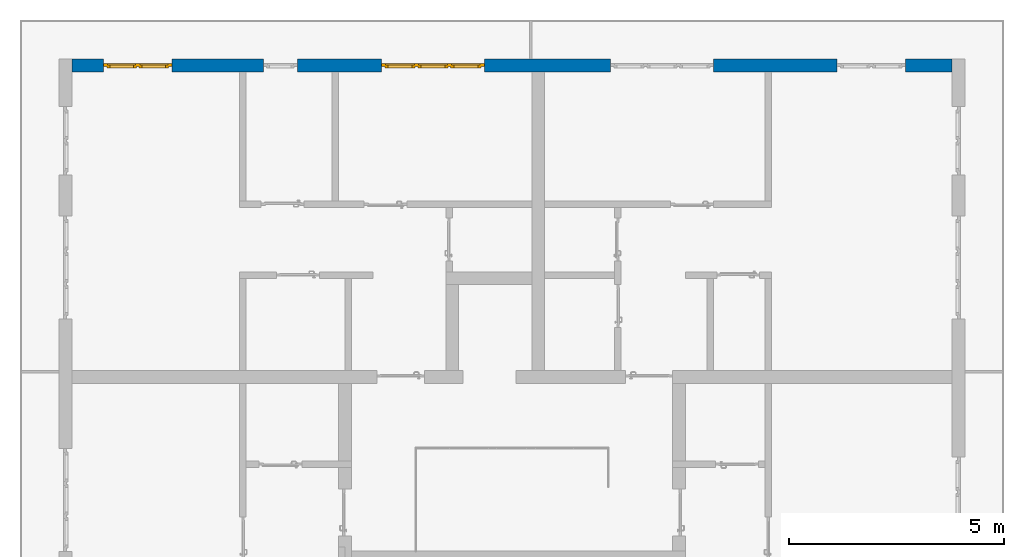
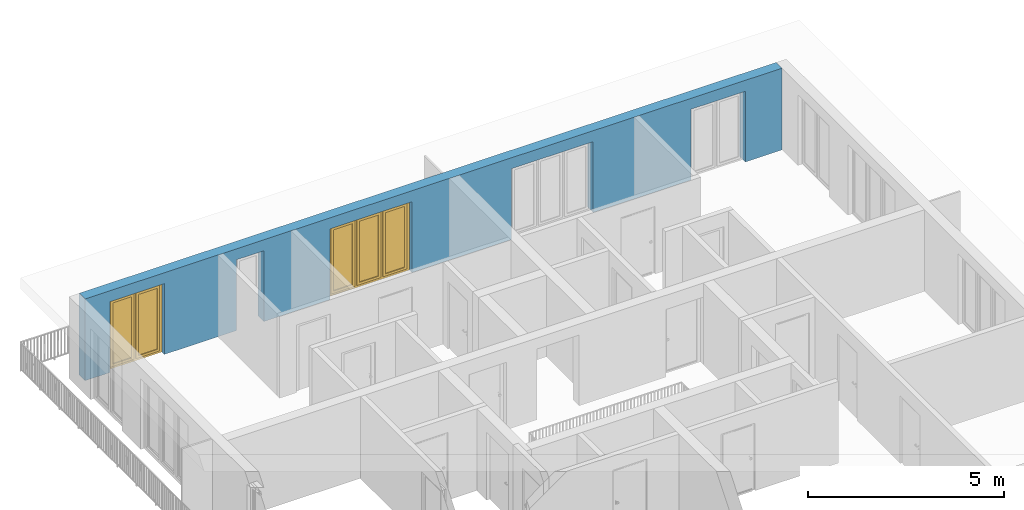
# One storey, part 27 of 54: 2 windows, 1 wall, 5 openings.
"""IFC4 building model written with IfcOpenShell, lengths in metres."""

from ifc_helpers import new_model, entity, si_unit, converted_unit, derived_unit, direction, frame, origin_with_axes, place, context, subcontext, project, spatial, polygons, source, transform, mapped, material, type_object, element, fill, save


model = new_model("IFC4")

# Units and contexts
model_context = context("Model", 3, precision=1e-05, world=origin_with_axes(), true_north=direction((0.0, 1.0)))
body_context = subcontext(model_context, "Body", "Model", "MODEL_VIEW")
ifc_project = project(units=[si_unit("LENGTHUNIT", "METRE"), si_unit("AREAUNIT", "SQUARE_METRE"), si_unit("VOLUMEUNIT", "CUBIC_METRE"), converted_unit("PLANEANGLEUNIT", "DEGREE", entity("IfcPlaneAngleMeasure", 0.0174532925199), si_unit("PLANEANGLEUNIT", "RADIAN"), dimensions=[0, 0, 0, 0, 0, 0, 0]), converted_unit("TIMEUNIT", "Year", entity("IfcTimeMeasure", 31556926.0), si_unit("TIMEUNIT", "SECOND"), dimensions=[0, 0, 1, 0, 0, 0, 0]), si_unit("MASSUNIT", "GRAM", prefix="KILO"), si_unit("THERMODYNAMICTEMPERATUREUNIT", "DEGREE_CELSIUS"), si_unit("LUMINOUSINTENSITYUNIT", "LUMEN"), si_unit("ENERGYUNIT", "JOULE", prefix="MEGA"), derived_unit("THERMALCONDUCTANCEUNIT", [(si_unit("POWERUNIT", "WATT"), 1), (si_unit("LENGTHUNIT", "METRE"), -1), (si_unit("THERMODYNAMICTEMPERATUREUNIT", "KELVIN"), -1)]), derived_unit("SPECIFICHEATCAPACITYUNIT", [(si_unit("ENERGYUNIT", "JOULE"), 1), (si_unit("MASSUNIT", "GRAM", prefix="KILO"), -1), (si_unit("THERMODYNAMICTEMPERATUREUNIT", "KELVIN"), -1)]), derived_unit("MASSDENSITYUNIT", [(si_unit("MASSUNIT", "GRAM", prefix="KILO"), 1), (si_unit("VOLUMEUNIT", "CUBIC_METRE"), -1)])], contexts=[model_context])

# Site, building, storey
site_placement = place(None, origin_with_axes())
site = spatial("IfcSite", under=ifc_project, at=site_placement, CompositionType="ELEMENT")
building_placement = place(site_placement, origin_with_axes())
building = spatial("IfcBuilding", under=site, at=building_placement, CompositionType="ELEMENT")
storey_placement = place(building_placement, frame((0.0, 0.0, 9.18), z_axis=(0.0, 0.0, 1.0), x_axis=(1.0, 0.0, 0.0)))
storey = spatial("IfcBuildingStorey", under=building, at=storey_placement, Name="3. Geschoss", CompositionType="ELEMENT", Elevation=9.18)

# Wall, openings, windows
ifc_material = material()
wall_type = type_object("IfcWallType", Name="300", PredefinedType="NOTDEFINED")
wall_placement = place(storey_placement, frame((-11.7421993804, 8.92118776896, 0.0), z_axis=(0.0, 0.0, 1.0), x_axis=(1.0, 0.0, 0.0)))
wall = element("IfcWall", 1, at=wall_placement, inside=storey, type_object=wall_type, material=ifc_material, Name="Wand-001", PredefinedType="NOTDEFINED", context=body_context, shape_type="Tessellation", body=[
    polygons([(15.23, -0.1, 0.0), (15.23, -0.3, 0.0), (15.23, -0.3, 2.2), (15.23, 0.0, 2.2), (15.23, 0.0, 0.0), (18.102139809, 0.0, 0.0), (18.102139809, -0.3, 0.0), (18.102139809, -0.3, 2.2), (19.702139809, -0.3, 2.2), (19.702139809, -0.3, 0.0), (20.78, -0.3, 0.0), (20.78, -0.3, 2.54), (0.3, -0.3, 2.54), (0.3, -0.3, 0.0), (1.0288518641, -0.3, 0.0), (1.0288518641, -0.3, 2.2), (2.6288518641, -0.3, 2.2), (2.6288518641, -0.3, 0.0), (4.75, -0.3, 0.0), (4.75, -0.3, 2.2), (5.55, -0.3, 2.2), (5.55, -0.3, 0.0), (7.50089858046, -0.3, 0.0), (7.50089858046, -0.3, 2.2), (9.90089858046, -0.3, 2.2), (9.90089858046, -0.3, 0.0), (12.83, -0.3, 0.0), (12.83, -0.3, 2.2), (12.83, 0.0, 2.2), (12.83, 0.0, 0.0), (9.90089858046, 0.0, 0.0), (9.90089858046, 0.0, 2.2), (7.50089858046, 0.0, 2.2), (7.50089858046, 0.0, 0.0), (5.55, 0.0, 0.0), (5.55, 0.0, 2.2), (4.75, 0.0, 2.2), (4.75, 0.0, 0.0), (2.6288518641, 0.0, 0.0), (2.6288518641, 0.0, 2.2), (1.0288518641, 0.0, 2.2), (1.0288518641, 0.0, 0.0), (0.3, 0.0, 0.0), (0.3, 0.0, 2.54), (20.78, 0.0, 2.54), (20.78, 0.0, 0.0), (19.702139809, 0.0, 0.0), (19.702139809, 0.0, 2.2), (18.102139809, 0.0, 2.2), (12.83, -0.1, 0.0)], [[[1, 2, 3, 4, 5]], [[2, 1, 5, 6, 7]], [[3, 2, 7, 8, 9, 10, 11, 12, 13, 14, 15, 16, 17, 18, 19, 20, 21, 22, 23, 24, 25, 26, 27, 28]], [[4, 3, 28, 29]], [[6, 5, 4, 29, 30, 31, 32, 33, 34, 35, 36, 37, 38, 39, 40, 41, 42, 43, 44, 45, 46, 47, 48, 49]], [[6, 49, 8, 7]], [[8, 49, 48, 9]], [[48, 47, 10, 9]], [[46, 11, 10, 47]], [[12, 11, 46, 45]], [[45, 44, 13, 12]], [[44, 43, 14, 13]], [[15, 14, 43, 42]], [[16, 15, 42, 41]], [[40, 17, 16, 41]], [[18, 17, 40, 39]], [[19, 18, 39, 38]], [[20, 19, 38, 37]], [[36, 21, 20, 37]], [[22, 21, 36, 35]], [[22, 35, 34, 23]], [[34, 33, 24, 23]], [[24, 33, 32, 25]], [[32, 31, 26, 25]], [[50, 27, 26, 31, 30]], [[28, 27, 50, 30, 29]]], closed=True),
])
opening_1_placement = place(wall_placement, frame((1.8288518641, 0.0, 0.0), z_axis=(0.0, 0.0, 1.0), x_axis=(1.0, 0.0, 0.0)))
opening_1 = element("IfcOpeningElement", 2, at=opening_1_placement, cuts=wall, Name="Fenster-001", context=body_context, identifier="Reference", shape_type="Tessellation", body=[
    polygons([(-0.8, -0.1, 0.0), (-0.8, -0.1, 2.2), (-0.8, 0.000999999999998, 2.2), (-0.8, 0.000999999999998, 0.0), (-0.8, -0.301, 0.0), (-0.8, -0.301, 2.2), (0.8, -0.1, 2.2), (0.8, 0.000999999999999, 2.2), (0.8, -0.301, 2.2), (0.8, 0.000999999999999, 0.0), (0.8, -0.1, 0.0), (0.8, -0.301, 0.0)], [[[1, 2, 3, 4]], [[2, 1, 5, 6]], [[7, 8, 3, 2, 6, 9]], [[8, 10, 4, 3]], [[1, 4, 10, 11, 12, 5]], [[6, 5, 12, 9]], [[7, 11, 10, 8]], [[11, 7, 9, 12]]], closed=True),
])
opening_2_placement = place(wall_placement, frame((8.70089858046, 0.0, 0.0), z_axis=(0.0, 0.0, 1.0), x_axis=(1.0, 0.0, 0.0)))
opening_2 = element("IfcOpeningElement", 3, at=opening_2_placement, cuts=wall, Name="Fenster-002", context=body_context, identifier="Reference", shape_type="Tessellation", body=[
    polygons([(-1.2, -0.1, 0.0), (-1.2, -0.1, 2.2), (-1.2, 0.000999999999999, 2.2), (-1.2, 0.000999999999999, 0.0), (-1.2, -0.301, 0.0), (-1.2, -0.301, 2.2), (1.2, -0.1, 2.2), (1.2, 0.001, 2.2), (1.2, -0.301, 2.2), (1.2, 0.001, 0.0), (1.2, -0.1, 0.0), (1.2, -0.301, 0.0)], [[[1, 2, 3, 4]], [[2, 1, 5, 6]], [[7, 8, 3, 2, 6, 9]], [[8, 10, 4, 3]], [[1, 4, 10, 11, 12, 5]], [[6, 5, 12, 9]], [[7, 11, 10, 8]], [[11, 7, 9, 12]]], closed=True),
])
opening_3_placement = place(wall_placement, frame((5.15, 0.0, 0.0), z_axis=(0.0, 0.0, 1.0), x_axis=(1.0, 0.0, 0.0)))
element("IfcOpeningElement", 4, at=opening_3_placement, cuts=wall, Name="Fenster-003", context=body_context, identifier="Reference", shape_type="Tessellation", body=[
    polygons([(-0.4, -0.1, 0.0), (-0.4, -0.1, 2.2), (-0.4, 0.001, 2.2), (-0.4, 0.001, 0.0), (-0.4, -0.301, 0.0), (-0.4, -0.301, 2.2), (0.4, -0.1, 2.2), (0.4, 0.001, 2.2), (0.4, -0.301, 2.2), (0.4, 0.001, 0.0), (0.4, -0.1, 0.0), (0.4, -0.301, 0.0)], [[[1, 2, 3, 4]], [[2, 1, 5, 6]], [[7, 8, 3, 2, 6, 9]], [[8, 10, 4, 3]], [[1, 4, 10, 11, 12, 5]], [[6, 5, 12, 9]], [[7, 11, 10, 8]], [[11, 7, 9, 12]]], closed=True),
])
opening_4_placement = place(wall_placement, frame((18.902139809, 0.0, 0.0), z_axis=(0.0, 0.0, 1.0), x_axis=(1.0, 0.0, 0.0)))
element("IfcOpeningElement", 5, at=opening_4_placement, cuts=wall, Name="Fenster-001", context=body_context, identifier="Reference", shape_type="Tessellation", body=[
    polygons([(-0.8, -0.1, 0.0), (-0.8, -0.1, 2.2), (-0.8, 0.001, 2.2), (-0.8, 0.001, 0.0), (-0.8, -0.301, 0.0), (-0.8, -0.301, 2.2), (0.8, -0.1, 2.2), (0.8, 0.001, 2.2), (0.8, -0.301, 2.2), (0.8, 0.001, 0.0), (0.8, -0.1, 0.0), (0.8, -0.301, 0.0)], [[[1, 2, 3, 4]], [[2, 1, 5, 6]], [[7, 8, 3, 2, 6, 9]], [[8, 10, 4, 3]], [[1, 4, 10, 11, 12, 5]], [[6, 5, 12, 9]], [[7, 11, 10, 8]], [[11, 7, 9, 12]]], closed=True),
])
opening_5_placement = place(wall_placement, frame((14.03, 0.0, 0.0), z_axis=(0.0, 0.0, 1.0), x_axis=(1.0, 0.0, 0.0)))
element("IfcOpeningElement", 6, at=opening_5_placement, cuts=wall, Name="Fenster-002", context=body_context, identifier="Reference", shape_type="Tessellation", body=[
    polygons([(-1.2, -0.1, 0.0), (-1.2, -0.1, 2.2), (-1.2, 0.001, 2.2), (-1.2, 0.001, 0.0), (-1.2, -0.301, 0.0), (-1.2, -0.301, 2.2), (1.2, -0.1, 2.2), (1.2, 0.001, 2.2), (1.2, -0.301, 2.2), (1.2, 0.001, 0.0), (1.2, -0.1, 0.0), (1.2, -0.301, 0.0)], [[[1, 2, 3, 4]], [[2, 1, 5, 6]], [[7, 8, 3, 2, 6, 9]], [[8, 10, 4, 3]], [[1, 4, 10, 11, 12, 5]], [[6, 5, 12, 9]], [[7, 11, 10, 8]], [[11, 7, 9, 12]]], closed=True),
])
window_type_1 = type_object("IfcWindowType", Name="2-1+1 26", PartitioningType="DOUBLE_PANEL_VERTICAL", PredefinedType="WINDOW")
shared_shape_1 = source(origin_with_axes(), body_context, "Body", "Tessellation", [
    polygons([(0.8, -0.07, 0.0), (0.7, -0.07, 0.1), (0.7, 0.0, 0.1), (0.8, 0.0, 0.0), (0.8, -0.07, 2.2), (0.7, -0.07, 2.1), (0.7, 0.0, 2.1), (0.8, 0.0, 2.2)], [[[1, 2, 3, 4]], [[1, 5, 6, 2]], [[2, 6, 7, 3]], [[4, 3, 7, 8]], [[5, 1, 4, 8]], [[6, 5, 8, 7]]], closed=True),
    polygons([(-0.8, -0.07, 0.0), (-0.8, -0.07, 2.2), (-0.8, 0.0, 2.2), (-0.8, 0.0, 0.0), (-0.7, -0.07, 0.1), (-0.7, -0.07, 2.1), (-0.7, 0.0, 2.1), (-0.7, 0.0, 0.1)], [[[1, 2, 3, 4]], [[1, 5, 6, 2]], [[2, 6, 7, 3]], [[4, 3, 7, 8]], [[5, 1, 4, 8]], [[6, 5, 8, 7]]], closed=True),
    polygons([(0.8, -0.07, 0.0), (-0.8, -0.07, 0.0), (-0.8, 0.0, 0.0), (0.8, 0.0, 0.0), (0.7, -0.07, 0.1), (0.05, -0.07, 0.1), (-0.05, -0.07, 0.1), (-0.7, -0.07, 0.1), (-0.7, 0.0, 0.1), (-0.05, 0.0, 0.1), (0.05, 0.0, 0.1), (0.7, 0.0, 0.1)], [[[1, 2, 3, 4]], [[1, 5, 6, 7, 8, 2]], [[2, 8, 9, 3]], [[4, 3, 9, 10, 11, 12]], [[5, 1, 4, 12]], [[6, 5, 12, 11]], [[7, 6, 11, 10]], [[8, 7, 10, 9]]], closed=True),
    polygons([(0.8, -0.07, 2.2), (0.7, -0.07, 2.1), (0.7, 0.0, 2.1), (0.8, 0.0, 2.2), (-0.8, -0.07, 2.2), (-0.7, -0.07, 2.1), (-0.05, -0.07, 2.1), (0.05, -0.07, 2.1), (0.05, 0.0, 2.1), (-0.05, 0.0, 2.1), (-0.7, 0.0, 2.1), (-0.8, 0.0, 2.2)], [[[1, 2, 3, 4]], [[1, 5, 6, 7, 8, 2]], [[2, 8, 9, 3]], [[4, 3, 9, 10, 11, 12]], [[5, 1, 4, 12]], [[6, 5, 12, 11]], [[7, 6, 11, 10]], [[8, 7, 10, 9]]], closed=True),
    polygons([(0.05, -0.07, 0.1), (-0.05, -0.07, 0.1), (-0.05, 0.0, 0.1), (0.05, 0.0, 0.1), (0.05, -0.07, 2.1), (-0.05, -0.07, 2.1), (-0.05, 0.0, 2.1), (0.05, 0.0, 2.1)], [[[1, 2, 3, 4]], [[1, 5, 6, 2]], [[2, 6, 7, 3]], [[4, 3, 7, 8]], [[5, 1, 4, 8]], [[6, 5, 8, 7]]], closed=True),
    polygons([(0.72, 0.0, 0.08), (0.65, 0.0, 0.15), (0.65, 0.03, 0.15), (0.72, 0.03, 0.08), (0.72, 0.0, 2.12), (0.65, 0.0, 2.05), (0.65, 0.03, 2.05), (0.72, 0.03, 2.12)], [[[1, 2, 3, 4]], [[1, 5, 6, 2]], [[2, 6, 7, 3]], [[4, 3, 7, 8]], [[5, 1, 4, 8]], [[6, 5, 8, 7]]], closed=True),
    polygons([(0.03, 0.0, 0.08), (0.03, 0.03, 0.08), (0.1, 0.03, 0.15), (0.1, 0.0, 0.15), (0.03, 0.0, 2.12), (0.03, 0.03, 2.12), (0.1, 0.03, 2.05), (0.1, 0.0, 2.05)], [[[1, 2, 3, 4]], [[5, 6, 2, 1]], [[2, 6, 7, 3]], [[4, 3, 7, 8]], [[1, 4, 8, 5]], [[8, 7, 6, 5]]], closed=True),
    polygons([(0.72, 0.0, 0.08), (0.03, 0.0, 0.08), (0.03, 0.03, 0.08), (0.72, 0.03, 0.08), (0.65, 0.0, 0.15), (0.1, 0.0, 0.15), (0.1, 0.03, 0.15), (0.65, 0.03, 0.15)], [[[1, 2, 3, 4]], [[1, 5, 6, 2]], [[2, 6, 7, 3]], [[4, 3, 7, 8]], [[5, 1, 4, 8]], [[6, 5, 8, 7]]], closed=True),
    polygons([(0.72, 0.0, 2.12), (0.72, 0.03, 2.12), (0.03, 0.03, 2.12), (0.03, 0.0, 2.12), (0.65, 0.0, 2.05), (0.65, 0.03, 2.05), (0.1, 0.03, 2.05), (0.1, 0.0, 2.05)], [[[1, 2, 3, 4]], [[5, 6, 2, 1]], [[2, 6, 7, 3]], [[4, 3, 7, 8]], [[1, 4, 8, 5]], [[8, 7, 6, 5]]], closed=True),
    polygons([(0.7, -0.03, 0.1), (0.65, -0.03, 0.15), (0.65, 0.0, 0.15), (0.7, 0.0, 0.1), (0.7, -0.03, 2.1), (0.65, -0.03, 2.05), (0.65, 0.0, 2.05), (0.7, 0.0, 2.1)], [[[1, 2, 3, 4]], [[1, 5, 6, 2]], [[2, 6, 7, 3]], [[4, 3, 7, 8]], [[5, 1, 4, 8]], [[6, 5, 8, 7]]], closed=True),
    polygons([(0.05, -0.03, 0.1), (0.05, 0.0, 0.1), (0.1, 0.0, 0.15), (0.1, -0.03, 0.15), (0.05, -0.03, 2.1), (0.05, 0.0, 2.1), (0.1, 0.0, 2.05), (0.1, -0.03, 2.05)], [[[1, 2, 3, 4]], [[5, 6, 2, 1]], [[2, 6, 7, 3]], [[4, 3, 7, 8]], [[1, 4, 8, 5]], [[8, 7, 6, 5]]], closed=True),
    polygons([(0.7, -0.03, 0.1), (0.05, -0.03, 0.1), (0.05, 0.0, 0.1), (0.7, 0.0, 0.1), (0.65, -0.03, 0.15), (0.1, -0.03, 0.15), (0.1, 0.0, 0.15), (0.65, 0.0, 0.15)], [[[1, 2, 3, 4]], [[1, 5, 6, 2]], [[2, 6, 7, 3]], [[4, 3, 7, 8]], [[5, 1, 4, 8]], [[6, 5, 8, 7]]], closed=True),
    polygons([(0.7, -0.03, 2.1), (0.7, 0.0, 2.1), (0.05, 0.0, 2.1), (0.05, -0.03, 2.1), (0.65, -0.03, 2.05), (0.65, 0.0, 2.05), (0.1, 0.0, 2.05), (0.1, -0.03, 2.05)], [[[1, 2, 3, 4]], [[5, 6, 2, 1]], [[2, 6, 7, 3]], [[4, 3, 7, 8]], [[1, 4, 8, 5]], [[8, 7, 6, 5]]], closed=True),
    polygons([(0.65, -0.005, 0.15), (0.1, -0.005, 0.15), (0.1, 0.005, 0.15), (0.65, 0.005, 0.15), (0.65, -0.005, 2.05), (0.1, -0.005, 2.05), (0.1, 0.005, 2.05), (0.65, 0.005, 2.05)], [[[1, 2, 3, 4]], [[1, 5, 6, 2]], [[2, 6, 7, 3]], [[4, 3, 7, 8]], [[5, 1, 4, 8]], [[6, 5, 8, 7]]], closed=True),
    polygons([(-0.03, 0.0, 0.08), (-0.1, 0.0, 0.15), (-0.1, 0.03, 0.15), (-0.03, 0.03, 0.08), (-0.03, 0.0, 2.12), (-0.1, 0.0, 2.05), (-0.1, 0.03, 2.05), (-0.03, 0.03, 2.12)], [[[1, 2, 3, 4]], [[1, 5, 6, 2]], [[2, 6, 7, 3]], [[4, 3, 7, 8]], [[5, 1, 4, 8]], [[6, 5, 8, 7]]], closed=True),
    polygons([(-0.72, 0.0, 0.08), (-0.72, 0.03, 0.08), (-0.65, 0.03, 0.15), (-0.65, 0.0, 0.15), (-0.72, 0.0, 2.12), (-0.72, 0.03, 2.12), (-0.65, 0.03, 2.05), (-0.65, 0.0, 2.05)], [[[1, 2, 3, 4]], [[5, 6, 2, 1]], [[2, 6, 7, 3]], [[4, 3, 7, 8]], [[1, 4, 8, 5]], [[8, 7, 6, 5]]], closed=True),
    polygons([(-0.03, 0.0, 0.08), (-0.72, 0.0, 0.08), (-0.72, 0.03, 0.08), (-0.03, 0.03, 0.08), (-0.1, 0.0, 0.15), (-0.65, 0.0, 0.15), (-0.65, 0.03, 0.15), (-0.1, 0.03, 0.15)], [[[1, 2, 3, 4]], [[1, 5, 6, 2]], [[2, 6, 7, 3]], [[4, 3, 7, 8]], [[5, 1, 4, 8]], [[6, 5, 8, 7]]], closed=True),
    polygons([(-0.03, 0.0, 2.12), (-0.03, 0.03, 2.12), (-0.72, 0.03, 2.12), (-0.72, 0.0, 2.12), (-0.1, 0.0, 2.05), (-0.1, 0.03, 2.05), (-0.65, 0.03, 2.05), (-0.65, 0.0, 2.05)], [[[1, 2, 3, 4]], [[5, 6, 2, 1]], [[2, 6, 7, 3]], [[4, 3, 7, 8]], [[1, 4, 8, 5]], [[8, 7, 6, 5]]], closed=True),
    polygons([(-0.05, -0.03, 0.1), (-0.1, -0.03, 0.15), (-0.1, 0.0, 0.15), (-0.05, 0.0, 0.1), (-0.05, -0.03, 2.1), (-0.1, -0.03, 2.05), (-0.1, 0.0, 2.05), (-0.05, 0.0, 2.1)], [[[1, 2, 3, 4]], [[1, 5, 6, 2]], [[2, 6, 7, 3]], [[4, 3, 7, 8]], [[5, 1, 4, 8]], [[6, 5, 8, 7]]], closed=True),
    polygons([(-0.7, -0.03, 0.1), (-0.7, 0.0, 0.1), (-0.65, 0.0, 0.15), (-0.65, -0.03, 0.15), (-0.7, -0.03, 2.1), (-0.7, 0.0, 2.1), (-0.65, 0.0, 2.05), (-0.65, -0.03, 2.05)], [[[1, 2, 3, 4]], [[5, 6, 2, 1]], [[2, 6, 7, 3]], [[4, 3, 7, 8]], [[1, 4, 8, 5]], [[8, 7, 6, 5]]], closed=True),
    polygons([(-0.05, -0.03, 0.1), (-0.7, -0.03, 0.1), (-0.7, 0.0, 0.1), (-0.05, 0.0, 0.1), (-0.1, -0.03, 0.15), (-0.65, -0.03, 0.15), (-0.65, 0.0, 0.15), (-0.1, 0.0, 0.15)], [[[1, 2, 3, 4]], [[1, 5, 6, 2]], [[2, 6, 7, 3]], [[4, 3, 7, 8]], [[5, 1, 4, 8]], [[6, 5, 8, 7]]], closed=True),
    polygons([(-0.05, -0.03, 2.1), (-0.05, 0.0, 2.1), (-0.7, 0.0, 2.1), (-0.7, -0.03, 2.1), (-0.1, -0.03, 2.05), (-0.1, 0.0, 2.05), (-0.65, 0.0, 2.05), (-0.65, -0.03, 2.05)], [[[1, 2, 3, 4]], [[5, 6, 2, 1]], [[2, 6, 7, 3]], [[4, 3, 7, 8]], [[1, 4, 8, 5]], [[8, 7, 6, 5]]], closed=True),
    polygons([(-0.1, -0.005, 0.15), (-0.65, -0.005, 0.15), (-0.65, 0.005, 0.15), (-0.1, 0.005, 0.15), (-0.1, -0.005, 2.05), (-0.65, -0.005, 2.05), (-0.65, 0.005, 2.05), (-0.1, 0.005, 2.05)], [[[1, 2, 3, 4]], [[1, 5, 6, 2]], [[2, 6, 7, 3]], [[4, 3, 7, 8]], [[5, 1, 4, 8]], [[6, 5, 8, 7]]], closed=True),
])
window_1_placement = place(opening_1_placement, frame((0.8, 0.0, 0.0), z_axis=(0.0, 0.0, 1.0), x_axis=(-1.0, 0.0, 0.0)))
window_1 = element("IfcWindow", 7, at=window_1_placement, inside=storey, type_object=window_type_1, Name="Fenster-001", OverallHeight=2.2, OverallWidth=1.6, PredefinedType="WINDOW", context=body_context, shape_type="MappedRepresentation", body=[
    mapped(shared_shape_1, transform((0.8, 0.17, 0.0))),
])
fill(opening_1, window_1)
window_type_2 = type_object("IfcWindowType", Name="3-1+1+1 26", PartitioningType="TRIPLE_PANEL_VERTICAL", PredefinedType="WINDOW")
shared_shape_2 = source(origin_with_axes(), body_context, "Body", "Tessellation", [
    polygons([(1.2, -0.07, 0.0), (1.1, -0.07, 0.1), (1.1, 0.0, 0.1), (1.2, 0.0, 0.0), (1.2, -0.07, 2.2), (1.1, -0.07, 2.1), (1.1, 0.0, 2.1), (1.2, 0.0, 2.2)], [[[1, 2, 3, 4]], [[1, 5, 6, 2]], [[2, 6, 7, 3]], [[4, 3, 7, 8]], [[5, 1, 4, 8]], [[6, 5, 8, 7]]], closed=True),
    polygons([(-1.2, -0.07, 0.0), (-1.2, -0.07, 2.2), (-1.2, 0.0, 2.2), (-1.2, 0.0, 0.0), (-1.1, -0.07, 0.1), (-1.1, -0.07, 2.1), (-1.1, 0.0, 2.1), (-1.1, 0.0, 0.1)], [[[1, 2, 3, 4]], [[1, 5, 6, 2]], [[2, 6, 7, 3]], [[4, 3, 7, 8]], [[5, 1, 4, 8]], [[6, 5, 8, 7]]], closed=True),
    polygons([(1.2, -0.07, 0.0), (-1.2, -0.07, 0.0), (-1.2, 0.0, 0.0), (1.2, 0.0, 0.0), (1.1, -0.07, 0.1), (0.433333333333, -0.07, 0.1), (0.333333333333, -0.07, 0.1), (-0.333333333333, -0.07, 0.1), (-0.433333333333, -0.07, 0.1), (-1.1, -0.07, 0.1), (-1.1, 0.0, 0.1), (-0.433333333333, 0.0, 0.1), (-0.333333333333, 0.0, 0.1), (0.333333333333, 0.0, 0.1), (0.433333333333, 0.0, 0.1), (1.1, 0.0, 0.1)], [[[1, 2, 3, 4]], [[1, 5, 6, 7, 8, 9, 10, 2]], [[2, 10, 11, 3]], [[4, 3, 11, 12, 13, 14, 15, 16]], [[5, 1, 4, 16]], [[6, 5, 16, 15]], [[7, 6, 15, 14]], [[8, 7, 14, 13]], [[9, 8, 13, 12]], [[10, 9, 12, 11]]], closed=True),
    polygons([(1.2, -0.07, 2.2), (1.1, -0.07, 2.1), (1.1, 0.0, 2.1), (1.2, 0.0, 2.2), (-1.2, -0.07, 2.2), (-1.1, -0.07, 2.1), (-0.433333333333, -0.07, 2.1), (-0.333333333333, -0.07, 2.1), (0.333333333333, -0.07, 2.1), (0.433333333333, -0.07, 2.1), (0.433333333333, 0.0, 2.1), (0.333333333333, 0.0, 2.1), (-0.333333333333, 0.0, 2.1), (-0.433333333333, 0.0, 2.1), (-1.1, 0.0, 2.1), (-1.2, 0.0, 2.2)], [[[1, 2, 3, 4]], [[1, 5, 6, 7, 8, 9, 10, 2]], [[2, 10, 11, 3]], [[4, 3, 11, 12, 13, 14, 15, 16]], [[5, 1, 4, 16]], [[6, 5, 16, 15]], [[7, 6, 15, 14]], [[8, 7, 14, 13]], [[9, 8, 13, 12]], [[10, 9, 12, 11]]], closed=True),
    polygons([(-0.333333333333, -0.07, 0.1), (-0.433333333333, -0.07, 0.1), (-0.433333333333, 0.0, 0.1), (-0.333333333333, 0.0, 0.1), (-0.333333333333, -0.07, 2.1), (-0.433333333333, -0.07, 2.1), (-0.433333333333, 0.0, 2.1), (-0.333333333333, 0.0, 2.1)], [[[1, 2, 3, 4]], [[1, 5, 6, 2]], [[2, 6, 7, 3]], [[4, 3, 7, 8]], [[5, 1, 4, 8]], [[6, 5, 8, 7]]], closed=True),
    polygons([(0.433333333333, -0.07, 0.1), (0.333333333333, -0.07, 0.1), (0.333333333333, 0.0, 0.1), (0.433333333333, 0.0, 0.1), (0.433333333333, -0.07, 2.1), (0.333333333333, -0.07, 2.1), (0.333333333333, 0.0, 2.1), (0.433333333333, 0.0, 2.1)], [[[1, 2, 3, 4]], [[1, 5, 6, 2]], [[2, 6, 7, 3]], [[4, 3, 7, 8]], [[5, 1, 4, 8]], [[6, 5, 8, 7]]], closed=True),
    polygons([(1.12, 0.0, 0.08), (1.05, 0.0, 0.15), (1.05, 0.03, 0.15), (1.12, 0.03, 0.08), (1.12, 0.0, 2.12), (1.05, 0.0, 2.05), (1.05, 0.03, 2.05), (1.12, 0.03, 2.12)], [[[1, 2, 3, 4]], [[1, 5, 6, 2]], [[2, 6, 7, 3]], [[4, 3, 7, 8]], [[5, 1, 4, 8]], [[6, 5, 8, 7]]], closed=True),
    polygons([(0.413333333333, 0.0, 0.08), (0.413333333333, 0.03, 0.08), (0.483333333333, 0.03, 0.15), (0.483333333333, 0.0, 0.15), (0.413333333333, 0.0, 2.12), (0.413333333333, 0.03, 2.12), (0.483333333333, 0.03, 2.05), (0.483333333333, 0.0, 2.05)], [[[1, 2, 3, 4]], [[5, 6, 2, 1]], [[2, 6, 7, 3]], [[4, 3, 7, 8]], [[1, 4, 8, 5]], [[8, 7, 6, 5]]], closed=True),
    polygons([(1.12, 0.0, 0.08), (0.413333333333, 0.0, 0.08), (0.413333333333, 0.03, 0.08), (1.12, 0.03, 0.08), (1.05, 0.0, 0.15), (0.483333333333, 0.0, 0.15), (0.483333333333, 0.03, 0.15), (1.05, 0.03, 0.15)], [[[1, 2, 3, 4]], [[1, 5, 6, 2]], [[2, 6, 7, 3]], [[4, 3, 7, 8]], [[5, 1, 4, 8]], [[6, 5, 8, 7]]], closed=True),
    polygons([(1.12, 0.0, 2.12), (1.12, 0.03, 2.12), (0.413333333333, 0.03, 2.12), (0.413333333333, 0.0, 2.12), (1.05, 0.0, 2.05), (1.05, 0.03, 2.05), (0.483333333333, 0.03, 2.05), (0.483333333333, 0.0, 2.05)], [[[1, 2, 3, 4]], [[5, 6, 2, 1]], [[2, 6, 7, 3]], [[4, 3, 7, 8]], [[1, 4, 8, 5]], [[8, 7, 6, 5]]], closed=True),
    polygons([(1.1, -0.03, 0.1), (1.05, -0.03, 0.15), (1.05, 0.0, 0.15), (1.1, 0.0, 0.1), (1.1, -0.03, 2.1), (1.05, -0.03, 2.05), (1.05, 0.0, 2.05), (1.1, 0.0, 2.1)], [[[1, 2, 3, 4]], [[1, 5, 6, 2]], [[2, 6, 7, 3]], [[4, 3, 7, 8]], [[5, 1, 4, 8]], [[6, 5, 8, 7]]], closed=True),
    polygons([(0.433333333333, -0.03, 0.1), (0.433333333333, 0.0, 0.1), (0.483333333333, 0.0, 0.15), (0.483333333333, -0.03, 0.15), (0.433333333333, -0.03, 2.1), (0.433333333333, 0.0, 2.1), (0.483333333333, 0.0, 2.05), (0.483333333333, -0.03, 2.05)], [[[1, 2, 3, 4]], [[5, 6, 2, 1]], [[2, 6, 7, 3]], [[4, 3, 7, 8]], [[1, 4, 8, 5]], [[8, 7, 6, 5]]], closed=True),
    polygons([(1.1, -0.03, 0.1), (0.433333333333, -0.03, 0.1), (0.433333333333, 0.0, 0.1), (1.1, 0.0, 0.1), (1.05, -0.03, 0.15), (0.483333333333, -0.03, 0.15), (0.483333333333, 0.0, 0.15), (1.05, 0.0, 0.15)], [[[1, 2, 3, 4]], [[1, 5, 6, 2]], [[2, 6, 7, 3]], [[4, 3, 7, 8]], [[5, 1, 4, 8]], [[6, 5, 8, 7]]], closed=True),
    polygons([(1.1, -0.03, 2.1), (1.1, 0.0, 2.1), (0.433333333333, 0.0, 2.1), (0.433333333333, -0.03, 2.1), (1.05, -0.03, 2.05), (1.05, 0.0, 2.05), (0.483333333333, 0.0, 2.05), (0.483333333333, -0.03, 2.05)], [[[1, 2, 3, 4]], [[5, 6, 2, 1]], [[2, 6, 7, 3]], [[4, 3, 7, 8]], [[1, 4, 8, 5]], [[8, 7, 6, 5]]], closed=True),
    polygons([(1.05, -0.005, 0.15), (0.483333333333, -0.005, 0.15), (0.483333333333, 0.005, 0.15), (1.05, 0.005, 0.15), (1.05, -0.005, 2.05), (0.483333333333, -0.005, 2.05), (0.483333333333, 0.005, 2.05), (1.05, 0.005, 2.05)], [[[1, 2, 3, 4]], [[1, 5, 6, 2]], [[2, 6, 7, 3]], [[4, 3, 7, 8]], [[5, 1, 4, 8]], [[6, 5, 8, 7]]], closed=True),
    polygons([(0.353333333333, 0.0, 0.08), (0.283333333333, 0.0, 0.15), (0.283333333333, 0.03, 0.15), (0.353333333333, 0.03, 0.08), (0.353333333333, 0.0, 2.12), (0.283333333333, 0.0, 2.05), (0.283333333333, 0.03, 2.05), (0.353333333333, 0.03, 2.12)], [[[1, 2, 3, 4]], [[1, 5, 6, 2]], [[2, 6, 7, 3]], [[4, 3, 7, 8]], [[5, 1, 4, 8]], [[6, 5, 8, 7]]], closed=True),
    polygons([(-0.353333333333, 0.0, 0.08), (-0.353333333333, 0.03, 0.08), (-0.283333333333, 0.03, 0.15), (-0.283333333333, 0.0, 0.15), (-0.353333333333, 0.0, 2.12), (-0.353333333333, 0.03, 2.12), (-0.283333333333, 0.03, 2.05), (-0.283333333333, 0.0, 2.05)], [[[1, 2, 3, 4]], [[5, 6, 2, 1]], [[2, 6, 7, 3]], [[4, 3, 7, 8]], [[1, 4, 8, 5]], [[8, 7, 6, 5]]], closed=True),
    polygons([(0.353333333333, 0.0, 0.08), (-0.353333333333, 0.0, 0.08), (-0.353333333333, 0.03, 0.08), (0.353333333333, 0.03, 0.08), (0.283333333333, 0.0, 0.15), (-0.283333333333, 0.0, 0.15), (-0.283333333333, 0.03, 0.15), (0.283333333333, 0.03, 0.15)], [[[1, 2, 3, 4]], [[1, 5, 6, 2]], [[2, 6, 7, 3]], [[4, 3, 7, 8]], [[5, 1, 4, 8]], [[6, 5, 8, 7]]], closed=True),
    polygons([(0.353333333333, 0.0, 2.12), (0.353333333333, 0.03, 2.12), (-0.353333333333, 0.03, 2.12), (-0.353333333333, 0.0, 2.12), (0.283333333333, 0.0, 2.05), (0.283333333333, 0.03, 2.05), (-0.283333333333, 0.03, 2.05), (-0.283333333333, 0.0, 2.05)], [[[1, 2, 3, 4]], [[5, 6, 2, 1]], [[2, 6, 7, 3]], [[4, 3, 7, 8]], [[1, 4, 8, 5]], [[8, 7, 6, 5]]], closed=True),
    polygons([(0.333333333333, -0.03, 0.1), (0.283333333333, -0.03, 0.15), (0.283333333333, 0.0, 0.15), (0.333333333333, 0.0, 0.1), (0.333333333333, -0.03, 2.1), (0.283333333333, -0.03, 2.05), (0.283333333333, 0.0, 2.05), (0.333333333333, 0.0, 2.1)], [[[1, 2, 3, 4]], [[1, 5, 6, 2]], [[2, 6, 7, 3]], [[4, 3, 7, 8]], [[5, 1, 4, 8]], [[6, 5, 8, 7]]], closed=True),
    polygons([(-0.333333333333, -0.03, 0.1), (-0.333333333333, 0.0, 0.1), (-0.283333333333, 0.0, 0.15), (-0.283333333333, -0.03, 0.15), (-0.333333333333, -0.03, 2.1), (-0.333333333333, 0.0, 2.1), (-0.283333333333, 0.0, 2.05), (-0.283333333333, -0.03, 2.05)], [[[1, 2, 3, 4]], [[5, 6, 2, 1]], [[2, 6, 7, 3]], [[4, 3, 7, 8]], [[1, 4, 8, 5]], [[8, 7, 6, 5]]], closed=True),
    polygons([(0.333333333333, -0.03, 0.1), (-0.333333333333, -0.03, 0.1), (-0.333333333333, 0.0, 0.1), (0.333333333333, 0.0, 0.1), (0.283333333333, -0.03, 0.15), (-0.283333333333, -0.03, 0.15), (-0.283333333333, 0.0, 0.15), (0.283333333333, 0.0, 0.15)], [[[1, 2, 3, 4]], [[1, 5, 6, 2]], [[2, 6, 7, 3]], [[4, 3, 7, 8]], [[5, 1, 4, 8]], [[6, 5, 8, 7]]], closed=True),
    polygons([(0.333333333333, -0.03, 2.1), (0.333333333333, 0.0, 2.1), (-0.333333333333, 0.0, 2.1), (-0.333333333333, -0.03, 2.1), (0.283333333333, -0.03, 2.05), (0.283333333333, 0.0, 2.05), (-0.283333333333, 0.0, 2.05), (-0.283333333333, -0.03, 2.05)], [[[1, 2, 3, 4]], [[5, 6, 2, 1]], [[2, 6, 7, 3]], [[4, 3, 7, 8]], [[1, 4, 8, 5]], [[8, 7, 6, 5]]], closed=True),
    polygons([(0.283333333333, -0.005, 0.15), (-0.283333333333, -0.005, 0.15), (-0.283333333333, 0.005, 0.15), (0.283333333333, 0.005, 0.15), (0.283333333333, -0.005, 2.05), (-0.283333333333, -0.005, 2.05), (-0.283333333333, 0.005, 2.05), (0.283333333333, 0.005, 2.05)], [[[1, 2, 3, 4]], [[1, 5, 6, 2]], [[2, 6, 7, 3]], [[4, 3, 7, 8]], [[5, 1, 4, 8]], [[6, 5, 8, 7]]], closed=True),
    polygons([(-0.413333333333, 0.0, 0.08), (-0.483333333333, 0.0, 0.15), (-0.483333333333, 0.03, 0.15), (-0.413333333333, 0.03, 0.08), (-0.413333333333, 0.0, 2.12), (-0.483333333333, 0.0, 2.05), (-0.483333333333, 0.03, 2.05), (-0.413333333333, 0.03, 2.12)], [[[1, 2, 3, 4]], [[1, 5, 6, 2]], [[2, 6, 7, 3]], [[4, 3, 7, 8]], [[5, 1, 4, 8]], [[6, 5, 8, 7]]], closed=True),
    polygons([(-1.12, 0.0, 0.08), (-1.12, 0.03, 0.08), (-1.05, 0.03, 0.15), (-1.05, 0.0, 0.15), (-1.12, 0.0, 2.12), (-1.12, 0.03, 2.12), (-1.05, 0.03, 2.05), (-1.05, 0.0, 2.05)], [[[1, 2, 3, 4]], [[5, 6, 2, 1]], [[2, 6, 7, 3]], [[4, 3, 7, 8]], [[1, 4, 8, 5]], [[8, 7, 6, 5]]], closed=True),
    polygons([(-0.413333333333, 0.0, 0.08), (-1.12, 0.0, 0.08), (-1.12, 0.03, 0.08), (-0.413333333333, 0.03, 0.08), (-0.483333333333, 0.0, 0.15), (-1.05, 0.0, 0.15), (-1.05, 0.03, 0.15), (-0.483333333333, 0.03, 0.15)], [[[1, 2, 3, 4]], [[1, 5, 6, 2]], [[2, 6, 7, 3]], [[4, 3, 7, 8]], [[5, 1, 4, 8]], [[6, 5, 8, 7]]], closed=True),
    polygons([(-0.413333333333, 0.0, 2.12), (-0.413333333333, 0.03, 2.12), (-1.12, 0.03, 2.12), (-1.12, 0.0, 2.12), (-0.483333333333, 0.0, 2.05), (-0.483333333333, 0.03, 2.05), (-1.05, 0.03, 2.05), (-1.05, 0.0, 2.05)], [[[1, 2, 3, 4]], [[5, 6, 2, 1]], [[2, 6, 7, 3]], [[4, 3, 7, 8]], [[1, 4, 8, 5]], [[8, 7, 6, 5]]], closed=True),
    polygons([(-0.433333333333, -0.03, 0.1), (-0.483333333333, -0.03, 0.15), (-0.483333333333, 0.0, 0.15), (-0.433333333333, 0.0, 0.1), (-0.433333333333, -0.03, 2.1), (-0.483333333333, -0.03, 2.05), (-0.483333333333, 0.0, 2.05), (-0.433333333333, 0.0, 2.1)], [[[1, 2, 3, 4]], [[1, 5, 6, 2]], [[2, 6, 7, 3]], [[4, 3, 7, 8]], [[5, 1, 4, 8]], [[6, 5, 8, 7]]], closed=True),
    polygons([(-1.1, -0.03, 0.1), (-1.1, 0.0, 0.1), (-1.05, 0.0, 0.15), (-1.05, -0.03, 0.15), (-1.1, -0.03, 2.1), (-1.1, 0.0, 2.1), (-1.05, 0.0, 2.05), (-1.05, -0.03, 2.05)], [[[1, 2, 3, 4]], [[5, 6, 2, 1]], [[2, 6, 7, 3]], [[4, 3, 7, 8]], [[1, 4, 8, 5]], [[8, 7, 6, 5]]], closed=True),
    polygons([(-0.433333333333, -0.03, 0.1), (-1.1, -0.03, 0.1), (-1.1, 0.0, 0.1), (-0.433333333333, 0.0, 0.1), (-0.483333333333, -0.03, 0.15), (-1.05, -0.03, 0.15), (-1.05, 0.0, 0.15), (-0.483333333333, 0.0, 0.15)], [[[1, 2, 3, 4]], [[1, 5, 6, 2]], [[2, 6, 7, 3]], [[4, 3, 7, 8]], [[5, 1, 4, 8]], [[6, 5, 8, 7]]], closed=True),
    polygons([(-0.433333333333, -0.03, 2.1), (-0.433333333333, 0.0, 2.1), (-1.1, 0.0, 2.1), (-1.1, -0.03, 2.1), (-0.483333333333, -0.03, 2.05), (-0.483333333333, 0.0, 2.05), (-1.05, 0.0, 2.05), (-1.05, -0.03, 2.05)], [[[1, 2, 3, 4]], [[5, 6, 2, 1]], [[2, 6, 7, 3]], [[4, 3, 7, 8]], [[1, 4, 8, 5]], [[8, 7, 6, 5]]], closed=True),
    polygons([(-0.483333333333, -0.005, 0.15), (-1.05, -0.005, 0.15), (-1.05, 0.005, 0.15), (-0.483333333333, 0.005, 0.15), (-0.483333333333, -0.005, 2.05), (-1.05, -0.005, 2.05), (-1.05, 0.005, 2.05), (-0.483333333333, 0.005, 2.05)], [[[1, 2, 3, 4]], [[1, 5, 6, 2]], [[2, 6, 7, 3]], [[4, 3, 7, 8]], [[5, 1, 4, 8]], [[6, 5, 8, 7]]], closed=True),
])
window_2_placement = place(opening_2_placement, frame((1.2, 0.0, 0.0), z_axis=(0.0, 0.0, 1.0), x_axis=(-1.0, 0.0, 0.0)))
window_2 = element("IfcWindow", 8, at=window_2_placement, inside=storey, type_object=window_type_2, Name="Fenster-002", OverallHeight=2.2, OverallWidth=2.4, PredefinedType="WINDOW", context=body_context, shape_type="MappedRepresentation", body=[
    mapped(shared_shape_2, transform((1.2, 0.17, 0.0))),
])
fill(opening_2, window_2)

save(model, "model.ifc")
